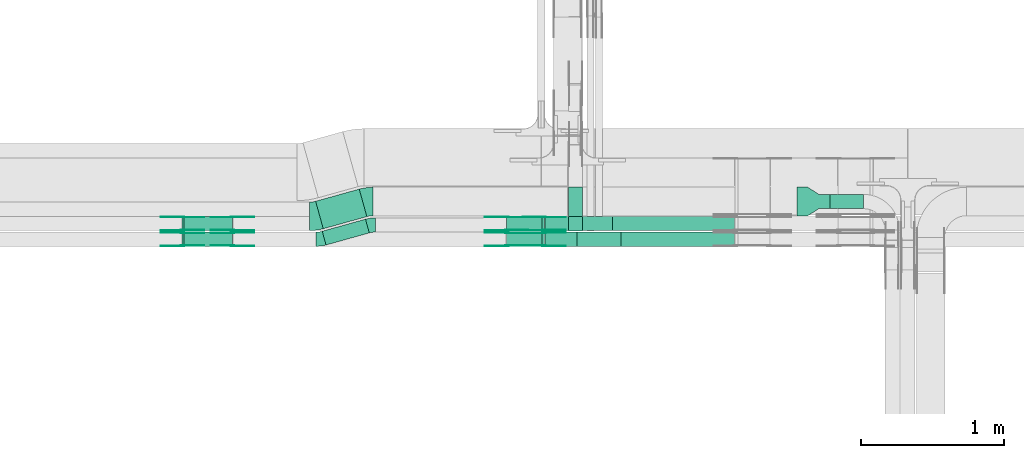
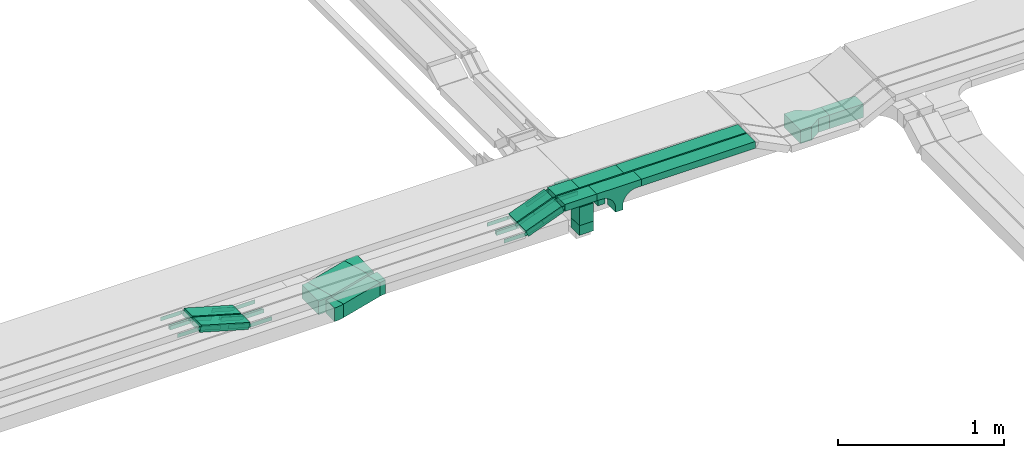
# One storey, part 21 of 28: 40 flow fittings, 12 flow segments.
"""IFC2X3 building model written with IfcOpenShell, lengths in millimetres."""

from ifc_helpers import new_model, entity, si_unit, converted_unit, derived_unit, direction, frame, frame_2d, origin, origin_2d_with_axis, place, context, subcontext, project, spatial, polyline, circle_curve, parameter, trimmed, segment, composite_curve, rectangle, outline, extrude, source, transform, mapped, material, material_list, type_object, type_shapes, element, save


model = new_model("IFC2X3")

# Units and contexts
model_context = context("Model", 3, precision=0.01, world=origin(), true_north=direction((6.12303176911189e-17, 1.0)))
body_context = subcontext(model_context, "Body", "Model", "MODEL_VIEW")
ifc_project = project(units=[si_unit("LENGTHUNIT", "METRE", prefix="MILLI"), si_unit("AREAUNIT", "SQUARE_METRE"), si_unit("VOLUMEUNIT", "CUBIC_METRE"), converted_unit("PLANEANGLEUNIT", "DEGREE", entity("IfcRatioMeasure", 0.0174532925199433), si_unit("PLANEANGLEUNIT", "RADIAN"), dimensions=[0, 0, 0, 0, 0, 0, 0]), si_unit("MASSUNIT", "GRAM", prefix="KILO"), derived_unit("MASSDENSITYUNIT", [(si_unit("MASSUNIT", "GRAM", prefix="KILO"), 1), (si_unit("LENGTHUNIT", "METRE"), -3)]), derived_unit("MOMENTOFINERTIAUNIT", [(si_unit("LENGTHUNIT", "METRE"), 4)]), si_unit("TIMEUNIT", "SECOND"), si_unit("FREQUENCYUNIT", "HERTZ"), si_unit("THERMODYNAMICTEMPERATUREUNIT", "DEGREE_CELSIUS"), derived_unit("THERMALTRANSMITTANCEUNIT", [(si_unit("MASSUNIT", "GRAM", prefix="KILO"), 1), (si_unit("THERMODYNAMICTEMPERATUREUNIT", "KELVIN"), -1), (si_unit("TIMEUNIT", "SECOND"), -3)]), derived_unit("VOLUMETRICFLOWRATEUNIT", [(si_unit("LENGTHUNIT", "METRE"), 3), (si_unit("TIMEUNIT", "SECOND"), -1)]), derived_unit("MASSFLOWRATEUNIT", [(si_unit("MASSUNIT", "GRAM", prefix="KILO"), 1), (si_unit("TIMEUNIT", "SECOND"), -1)]), derived_unit("ROTATIONALFREQUENCYUNIT", [(si_unit("TIMEUNIT", "SECOND"), -1)]), si_unit("ELECTRICCURRENTUNIT", "AMPERE"), si_unit("ELECTRICVOLTAGEUNIT", "VOLT"), si_unit("POWERUNIT", "WATT"), si_unit("FORCEUNIT", "NEWTON", prefix="KILO"), si_unit("ILLUMINANCEUNIT", "LUX"), si_unit("LUMINOUSFLUXUNIT", "LUMEN"), si_unit("LUMINOUSINTENSITYUNIT", "CANDELA"), derived_unit("USERDEFINED", [(si_unit("MASSUNIT", "GRAM", prefix="KILO"), -1), (si_unit("LENGTHUNIT", "METRE"), -2), (si_unit("TIMEUNIT", "SECOND"), 3), (si_unit("LUMINOUSFLUXUNIT", "LUMEN"), 1)]), derived_unit("LINEARVELOCITYUNIT", [(si_unit("LENGTHUNIT", "METRE"), 1), (si_unit("TIMEUNIT", "SECOND"), -1)]), si_unit("PRESSUREUNIT", "PASCAL"), derived_unit("USERDEFINED", [(si_unit("LENGTHUNIT", "METRE"), -2), (si_unit("MASSUNIT", "GRAM", prefix="KILO"), 1), (si_unit("TIMEUNIT", "SECOND"), -2)]), derived_unit("LINEARFORCEUNIT", [(si_unit("MASSUNIT", "GRAM", prefix="KILO"), 1), (si_unit("LENGTHUNIT", "METRE"), 1), (si_unit("TIMEUNIT", "SECOND"), -2), (si_unit("LENGTHUNIT", "METRE"), -1)]), derived_unit("PLANARFORCEUNIT", [(si_unit("MASSUNIT", "GRAM", prefix="KILO"), 1), (si_unit("LENGTHUNIT", "METRE"), 1), (si_unit("TIMEUNIT", "SECOND"), -2), (si_unit("LENGTHUNIT", "METRE"), -2)])], contexts=[model_context])

# Site, building, storey
site_placement = place(None, frame((0.0, -0.00077364408347762, 0.0)))
site = spatial("IfcSite", under=ifc_project, at=site_placement, CompositionType="ELEMENT")
building_placement = place(site_placement, origin())
building = spatial("IfcBuilding", under=site, at=building_placement, CompositionType="ELEMENT")
storey_placement = place(building_placement, origin())
storey = spatial("IfcBuildingStorey", under=building, at=storey_placement, CompositionType="ELEMENT", Elevation=0.0)

# Flow segments
cable_carrier_segment_type = type_object("IfcCableCarrierSegmentType", PredefinedType="CABLETRAYSEGMENT")
flow_segment_1_placement = place(storey_placement, frame((62283.4445429629, 8309.64525919694, 2600.0)))
element("IfcFlowSegment", 1, at=flow_segment_1_placement, inside=storey, type_object=cable_carrier_segment_type, context=body_context, shape_type="SweptSolid", body=[
    extrude(rectangle(XDim=314.534339130373, YDim=99.9999999999995, at=frame_2d((-4.14956957683899e-12, 1.16173737296776e-12), x_axis=(1.0, 0.0))), frame((164.919428102282, 90.4406635474246, 0.0), z_axis=(0.0, 0.0, 1.0), x_axis=(0.963181508900073, 0.268851968400788, 0.0)), (0.0, 0.0, 1.0), 100.0),
])
flow_segment_2_placement = place(storey_placement, frame((62237.2940815141, 8423.32710830691, 2600.0)))
element("IfcFlowSegment", 2, at=flow_segment_2_placement, inside=storey, type_object=cable_carrier_segment_type, context=body_context, shape_type="SweptSolid", body=[
    extrude(rectangle(XDim=316.935834936436, YDim=199.999999999999, at=frame_2d((4.02167188440217e-12, -1.69819713846664e-12), x_axis=(1.0, 0.0))), frame((179.518564699363, 138.922562429709, 0.0), z_axis=(0.0, 0.0, 1.0), x_axis=(0.963181508900077, 0.268851968400775, 0.0)), (0.0, 0.0, 1.0), 99.9999999999999),
])
flow_segment_3_placement = place(storey_placement, frame((64007.7697248974, 8409.3275570197, 2550.0)))
element("IfcFlowSegment", 3, at=flow_segment_3_placement, inside=storey, type_object=cable_carrier_segment_type, context=body_context, shape_type="SweptSolid", body=[
    extrude(rectangle(XDim=99.9999999999946, YDim=100.000000000001, at=origin_2d_with_axis()), frame((50.0, 50.0, 0.0), z_axis=(0.0, 0.0, 1.0), x_axis=(-1.0, 0.0, 0.0)), (0.0, 0.0, 1.0), 70.9999999978977),
])
flow_segment_4_placement = place(storey_placement, frame((61302.9475878774, 8410.00006103511, 2752.36750577514)))
element("IfcFlowSegment", 4, at=flow_segment_4_placement, inside=storey, type_object=cable_carrier_segment_type, context=body_context, shape_type="SweptSolid", body=[
    extrude(rectangle(XDim=49.9999999999995, YDim=100.000000000001, at=frame_2d((0.0, -5.20472553944273e-13), x_axis=(0.0, 1.0))), frame((6.89093389544473, 50.0, 121.233446051265), z_axis=(0.96126169593834, 0.0, -0.275637355816926), x_axis=(0.0, 1.0, 0.0)), (0.0, 0.0, 1.0), 352.64415944179),
])
flow_segment_5_placement = place(storey_placement, frame((61302.9475878774, 8300.0000610352, 2752.36750577514)))
element("IfcFlowSegment", 5, at=flow_segment_5_placement, inside=storey, type_object=cable_carrier_segment_type, context=body_context, shape_type="SweptSolid", body=[
    extrude(rectangle(XDim=49.9999999999984, YDim=99.9999999999989, at=frame_2d((0.0, 0.0), x_axis=(0.0, 1.0))), frame((6.89093389542741, 50.0, 121.233446051261), z_axis=(0.961261695938338, 0.0, -0.275637355816932), x_axis=(0.0, 1.0, 0.0)), (0.0, 0.0, 1.0), 352.644159441781),
])
flow_segment_6_placement = place(storey_placement, frame((65838.1697248974, 8564.3275570197, 2600.0)))
element("IfcFlowSegment", 6, at=flow_segment_6_placement, inside=storey, type_object=cable_carrier_segment_type, context=body_context, shape_type="SweptSolid", body=[
    extrude(rectangle(XDim=235.827601762733, YDim=100.000000000001, at=frame_2d((4.32720526077901e-12, 0.0), x_axis=(1.0, 0.0))), frame((117.913800881371, 50.0, 0.0)), (0.0, 0.0, 1.0), 100.0),
])
flow_segment_7_placement = place(storey_placement, frame((63843.5437252525, 8410.00006103521, 2850.0)))
element("IfcFlowSegment", 7, at=flow_segment_7_placement, inside=storey, type_object=cable_carrier_segment_type, context=body_context, shape_type="SweptSolid", body=[
    extrude(rectangle(XDim=163.625167697005, YDim=100.000000000001, at=frame_2d((0.0, -5.43565192856477e-13), x_axis=(1.0, 0.0))), frame((81.8125838484937, 50.0, 0.0), z_axis=(0.0, 0.0, 1.0), x_axis=(-1.0, 0.0, 0.0)), (0.0, 0.0, 1.0), 50.0000000000005),
])
flow_segment_8_placement = place(storey_placement, frame((63573.652206402, 8410.00006103521, 2753.94502491864)))
element("IfcFlowSegment", 8, at=flow_segment_8_placement, inside=storey, type_object=cable_carrier_segment_type, context=body_context, shape_type="SweptSolid", body=[
    extrude(rectangle(XDim=50.0000000000014, YDim=100.000000000001, at=origin_2d_with_axis()), frame((8.95919873865271, 50.0, 23.3395106624263), z_axis=(0.933580426496962, 0.0, 0.358367949545925), x_axis=(-0.358367949545925, 0.0, 0.933580426496962)), (0.0, 0.0, 1.0), 266.293146356256),
])
flow_segment_9_placement = place(storey_placement, frame((63843.5437252524, 8300.00006103516, 2850.0)))
element("IfcFlowSegment", 9, at=flow_segment_9_placement, inside=storey, type_object=cable_carrier_segment_type, context=body_context, shape_type="SweptSolid", body=[
    extrude(rectangle(XDim=223.777178948546, YDim=99.9999999999989, at=frame_2d((-4.33431068813661e-12, 0.0), x_axis=(1.0, 0.0))), frame((111.888589474277, 50.0, 0.0)), (0.0, 0.0, 1.0), 50.0),
])
flow_segment_10_placement = place(storey_placement, frame((63573.6522064018, 8300.00006103517, 2753.94502491862)))
element("IfcFlowSegment", 10, at=flow_segment_10_placement, inside=storey, type_object=cable_carrier_segment_type, context=body_context, shape_type="SweptSolid", body=[
    extrude(rectangle(XDim=50.0000000000008, YDim=100.000000000001, at=origin_2d_with_axis()), frame((8.95919873864405, 50.0, 23.339510662429), z_axis=(0.933580426497027, 0.0, 0.358367949545756), x_axis=(-0.358367949545756, 0.0, 0.933580426497027)), (0.0, 0.0, 1.0), 266.293146356433),
])
flow_segment_11_placement = place(storey_placement, frame((64317.1688929495, 8410.0000610352, 2850.0)))
element("IfcFlowSegment", 11, at=flow_segment_11_placement, inside=storey, type_object=cable_carrier_segment_type, context=body_context, shape_type="SweptSolid", body=[
    extrude(rectangle(XDim=853.173988896064, YDim=100.000000000001, at=frame_2d((4.32009983342141e-12, 0.0), x_axis=(1.0, 0.0))), frame((426.586994448036, 50.0, 0.0)), (0.0, 0.0, 1.0), 49.9999999999989),
])
flow_segment_12_placement = place(storey_placement, frame((64377.320904201, 8300.00006103515, 2850.0)))
element("IfcFlowSegment", 12, at=flow_segment_12_placement, inside=storey, type_object=cable_carrier_segment_type, context=body_context, shape_type="SweptSolid", body=[
    extrude(rectangle(XDim=793.021977644722, YDim=100.000000000001, at=frame_2d((-4.32009983342141e-12, -5.43565192856477e-13), x_axis=(1.0, 0.0))), frame((396.510988822374, 50.0, 0.0)), (0.0, 0.0, 1.0), 49.9999999999995),
])

# Flow fittings
ifc_material_1 = material(Name="G")
cable_carrier_fitting_type_1 = type_object("IfcCableCarrierFittingType", PredefinedType="NOTDEFINED", material=ifc_material_1)
shared_shape_1 = source(origin(), body_context, "Body", "SweptSolid", [
    extrude(outline(composite_curve([segment(trimmed(circle_curve(frame_2d((-44.5901162790698, 0.0), x_axis=(1.0, 0.0)), 12.5), [parameter(90.0000000000007)], [parameter(270.0)], True, "PARAMETER"), True, "CONTINUOUS"), segment(polyline([(-44.5901162790697, -12.5), (-33.0901162790698, -12.5)]), True, "CONTINUOUS"), segment(polyline([(-33.0901162790698, -12.5), (-31.2296511627907, -14.5)]), True, "CONTINUOUS"), segment(polyline([(-31.2296511627907, -14.5), (108.90988372093, -14.5)]), True, "CONTINUOUS"), segment(polyline([(108.90988372093, -14.5), (108.90988372093, 14.5)]), True, "CONTINUOUS"), segment(polyline([(108.90988372093, 14.5), (-31.2296511627907, 14.5)]), True, "CONTINUOUS"), segment(polyline([(-31.2296511627907, 14.5), (-33.0901162790698, 12.5)]), True, "CONTINUOUS"), segment(polyline([(-33.0901162790698, 12.5), (-44.5901162790699, 12.5)]), True, "CONTINUOUS")], self_intersect=False)), frame((44.5901162790698, 0.0, 0.0), z_axis=(0.0, 0.0, -1.0), x_axis=(1.0, 0.0, 0.0)), (0.0, 0.0, -1.0), 2.0),
])
type_shapes(cable_carrier_fitting_type_1, [shared_shape_1])
for number, where, z_axis, x_axis in (
    (13, (63837.1688929494, 8414.54006102506, 2875.0), (0.0, -1.0, 0.0), (-0.933580426497204, 0.0, -0.358367949545295)),
    (14, (61653.7009053488, 8414.54006102508, 2775.0), (0.0, -1.0, 0.0), (1.0, 0.0, 0.0)),
    (15, (63576.6599864804, 8505.46006104539, 2775.0), (0.0, 1.0, 0.0), (-1.0, 0.0, 0.0)),
    (16, (61653.7009053489, 8304.54006102504, 2775.0), (0.0, -1.0, 0.0), (1.0, 0.0, 0.0)),
    (17, (63576.6599864802, 8395.46006104535, 2775.0), (0.0, 1.0, 0.0), (-1.0, 0.0, 0.0)),
    (18, (63837.1688929494, 8395.46006104533, 2875.0), (0.0, 1.0, 0.0), (1.0, 0.0, 0.0)),
    (19, (61304.9594609646, 8414.54006102495, 2875.0), (0.0, -1.0, 0.0), (-1.0, 0.0, 0.0)),
    (20, (61304.9594609646, 8304.54006102507, 2875.0), (0.0, -1.0, 0.0), (-1.0, 0.0, 0.0)),
):
    element("IfcFlowFitting", number, at=place(storey_placement, frame(where, z_axis=z_axis, x_axis=x_axis)), inside=storey, type_object=cable_carrier_fitting_type_1, material=ifc_material_1, context=body_context, shape_type="MappedRepresentation", body=[
        mapped(shared_shape_1, transform((0.0, 0.0, 0.0), scale=1.0)),
    ])
cable_carrier_fitting_type_2 = type_object("IfcCableCarrierFittingType", PredefinedType="NOTDEFINED", material=ifc_material_1)
shared_shape_2 = source(origin(), body_context, "Body", "SweptSolid", [
    extrude(outline(composite_curve([segment(trimmed(circle_curve(frame_2d((-44.5901162790697, 0.0), x_axis=(1.0, 0.0)), 12.5), [parameter(90.0000000000007)], [parameter(270.0)], True, "PARAMETER"), True, "CONTINUOUS"), segment(polyline([(-44.5901162790697, -12.5), (-33.0901162790697, -12.5)]), True, "CONTINUOUS"), segment(polyline([(-33.0901162790697, -12.5), (-31.2296511627907, -14.5)]), True, "CONTINUOUS"), segment(polyline([(-31.2296511627907, -14.5), (108.90988372093, -14.5)]), True, "CONTINUOUS"), segment(polyline([(108.90988372093, -14.5), (108.90988372093, 14.5)]), True, "CONTINUOUS"), segment(polyline([(108.90988372093, 14.5), (-31.2296511627907, 14.5)]), True, "CONTINUOUS"), segment(polyline([(-31.2296511627907, 14.5), (-33.0901162790698, 12.5)]), True, "CONTINUOUS"), segment(polyline([(-33.0901162790698, 12.5), (-44.5901162790699, 12.5)]), True, "CONTINUOUS")], self_intersect=False)), frame((44.5901162790697, 0.0, 0.0)), (0.0, 0.0, 1.0), 2.0),
])
type_shapes(cable_carrier_fitting_type_2, [shared_shape_2])
for number, where, z_axis, x_axis in (
    (21, (63837.1688929494, 8505.46006104537, 2875.0), (0.0, 1.0, 0.0), (-0.933580426497204, 0.0, -0.358367949545295)),
    (22, (61653.7009053488, 8505.4600610454, 2775.0), (0.0, 1.0, 0.0), (1.0, 0.0, 0.0)),
    (23, (63576.6599864804, 8414.54006102508, 2775.0), (0.0, -1.0, 0.0), (-1.0, 0.0, 0.0)),
    (24, (61653.7009053489, 8395.46006104536, 2775.0), (0.0, 1.0, 0.0), (1.0, 0.0, 0.0)),
    (25, (63576.6599864802, 8304.54006102503, 2775.0), (0.0, -1.0, 0.0), (-1.0, 0.0, 0.0)),
    (26, (63837.1688929494, 8304.54006102501, 2875.0), (0.0, -1.0, 0.0), (1.0, 0.0, 0.0)),
    (27, (61304.9594609646, 8505.46006104527, 2875.0), (0.0, 1.0, 0.0), (-1.0, 0.0, 0.0)),
    (28, (61304.9594609646, 8395.46006104539, 2875.0), (0.0, 1.0, 0.0), (-1.0, 0.0, 0.0)),
):
    element("IfcFlowFitting", number, at=place(storey_placement, frame(where, z_axis=z_axis, x_axis=x_axis)), inside=storey, type_object=cable_carrier_fitting_type_2, material=ifc_material_1, context=body_context, shape_type="MappedRepresentation", body=[
        mapped(shared_shape_2, transform((0.0, 0.0, 0.0), scale=1.0)),
    ])
cable_carrier_fitting_type_3 = type_object("IfcCableCarrierFittingType", PredefinedType="NOTDEFINED", material=ifc_material_1)
shared_shape_3 = source(origin(), body_context, "Body", "SweptSolid", [
    extrude(outline(composite_curve([segment(trimmed(circle_curve(frame_2d((-44.5901162790698, 0.0), x_axis=(1.0, 0.0)), 12.5), [parameter(90.0000000000007)], [parameter(270.0)], True, "PARAMETER"), True, "CONTINUOUS"), segment(polyline([(-44.5901162790697, -12.5), (-33.0901162790698, -12.5)]), True, "CONTINUOUS"), segment(polyline([(-33.0901162790698, -12.5), (-31.2296511627907, -14.5)]), True, "CONTINUOUS"), segment(polyline([(-31.2296511627907, -14.5), (108.90988372093, -14.5)]), True, "CONTINUOUS"), segment(polyline([(108.90988372093, -14.5), (108.90988372093, 14.5)]), True, "CONTINUOUS"), segment(polyline([(108.90988372093, 14.5), (-31.2296511627907, 14.5)]), True, "CONTINUOUS"), segment(polyline([(-31.2296511627907, 14.5), (-33.0901162790698, 12.5)]), True, "CONTINUOUS"), segment(polyline([(-33.0901162790698, 12.5), (-44.5901162790699, 12.5)]), True, "CONTINUOUS")], self_intersect=False)), frame((44.5901162790698, 0.0, 0.0), z_axis=(0.0, 0.0, -1.0), x_axis=(1.0, 0.0, 0.0)), (0.0, 0.0, -1.0), 2.0),
])
type_shapes(cable_carrier_fitting_type_3, [shared_shape_3])
for number, where, z_axis, x_axis in (
    (29, (63837.1688929494, 8503.46006104537, 2875.0), (0.0, 1.0, 0.0), (1.0, 0.0, 0.0)),
    (30, (61653.7009053489, 8503.4600610454, 2775.0), (0.0, 1.0, 0.0), (-0.961261695938351, 0.0, 0.275637355816886)),
    (31, (63576.6599864803, 8416.54006102507, 2775.0), (0.0, -1.0, 0.0), (0.93358042649699, 0.0, 0.358367949545852)),
    (32, (61653.7009053489, 8393.46006104536, 2775.0), (0.0, 1.0, 0.0), (-0.961261695938352, 0.0, 0.275637355816883)),
    (33, (63576.6599864802, 8306.54006102503, 2775.0), (0.0, -1.0, 0.0), (0.933580426497054, 0.0, 0.358367949545685)),
    (34, (63837.1688929494, 8306.54006102501, 2875.0), (0.0, -1.0, 0.0), (-0.933580426497046, 0.0, -0.358367949545707)),
    (35, (61304.9594609646, 8503.46006104527, 2875.0), (0.0, 1.0, 0.0), (0.961261695938351, 0.0, -0.275637355816886)),
    (36, (61304.9594609646, 8393.46006104539, 2875.0), (0.0, 1.0, 0.0), (0.961261695938352, 0.0, -0.275637355816883)),
):
    element("IfcFlowFitting", number, at=place(storey_placement, frame(where, z_axis=z_axis, x_axis=x_axis)), inside=storey, type_object=cable_carrier_fitting_type_3, material=ifc_material_1, context=body_context, shape_type="MappedRepresentation", body=[
        mapped(shared_shape_3, transform((0.0, 0.0, 0.0), scale=1.0)),
    ])
cable_carrier_fitting_type_4 = type_object("IfcCableCarrierFittingType", PredefinedType="NOTDEFINED", material=ifc_material_1)
shared_shape_4 = source(origin(), body_context, "Body", "SweptSolid", [
    extrude(outline(composite_curve([segment(trimmed(circle_curve(frame_2d((-44.5901162790697, 0.0), x_axis=(1.0, 0.0)), 12.5), [parameter(90.0000000000007)], [parameter(270.0)], True, "PARAMETER"), True, "CONTINUOUS"), segment(polyline([(-44.5901162790697, -12.5), (-33.0901162790697, -12.5)]), True, "CONTINUOUS"), segment(polyline([(-33.0901162790697, -12.5), (-31.2296511627907, -14.5)]), True, "CONTINUOUS"), segment(polyline([(-31.2296511627907, -14.5), (108.90988372093, -14.5)]), True, "CONTINUOUS"), segment(polyline([(108.90988372093, -14.5), (108.90988372093, 14.5)]), True, "CONTINUOUS"), segment(polyline([(108.90988372093, 14.5), (-31.2296511627907, 14.5)]), True, "CONTINUOUS"), segment(polyline([(-31.2296511627907, 14.5), (-33.0901162790698, 12.5)]), True, "CONTINUOUS"), segment(polyline([(-33.0901162790698, 12.5), (-44.5901162790699, 12.5)]), True, "CONTINUOUS")], self_intersect=False)), frame((44.5901162790697, 0.0, 0.0)), (0.0, 0.0, 1.0), 2.0),
])
type_shapes(cable_carrier_fitting_type_4, [shared_shape_4])
for number, where, z_axis, x_axis in (
    (37, (63837.1688929494, 8416.54006102506, 2875.0), (0.0, -1.0, 0.0), (1.0, 0.0, 0.0)),
    (38, (61653.7009053489, 8416.54006102509, 2775.0), (0.0, -1.0, 0.0), (-0.961261695938351, 0.0, 0.275637355816886)),
    (39, (63576.6599864803, 8503.46006104539, 2775.0), (0.0, 1.0, 0.0), (0.93358042649699, 0.0, 0.358367949545852)),
    (40, (61653.7009053489, 8306.54006102504, 2775.0), (0.0, -1.0, 0.0), (-0.961261695938352, 0.0, 0.275637355816883)),
    (41, (63576.6599864802, 8393.46006104534, 2775.0), (0.0, 1.0, 0.0), (0.933580426497054, 0.0, 0.358367949545685)),
    (42, (63837.1688929494, 8393.46006104533, 2875.0), (0.0, 1.0, 0.0), (-0.933580426497046, 0.0, -0.358367949545707)),
    (43, (61304.9594609646, 8416.54006102496, 2875.0), (0.0, -1.0, 0.0), (0.961261695938351, 0.0, -0.275637355816886)),
    (44, (61304.9594609646, 8306.54006102507, 2875.0), (0.0, -1.0, 0.0), (0.961261695938352, 0.0, -0.275637355816883)),
):
    element("IfcFlowFitting", number, at=place(storey_placement, frame(where, z_axis=z_axis, x_axis=x_axis)), inside=storey, type_object=cable_carrier_fitting_type_4, material=ifc_material_1, context=body_context, shape_type="MappedRepresentation", body=[
        mapped(shared_shape_4, transform((0.0, 0.0, 0.0), scale=1.0)),
    ])
ifc_material_2 = material()
cable_carrier_fitting_type_5 = type_object("IfcCableCarrierFittingType", Name="470_DKC_S5_Variable Angle Elbow 0-45:-", PredefinedType="NOTDEFINED", material=ifc_material_2)
shared_shape_5 = source(origin(), body_context, "Body", "SweptSolid", [
    extrude(outline(composite_curve([segment(polyline([(-27.8759922173, -53.7490621020919), (-26.8759922172987, -53.7490621020919)]), True, "CONTINUOUS"), segment(trimmed(circle_curve(frame_2d((-26.8759922173012, 196.250937897908), x_axis=(0.0, -1.0)), 250.0), [parameter(0.0)], [parameter(15.5959637059961)], True, "PARAMETER"), True, "CONTINUOUS"), segment(polyline([(40.3369998828871, -44.5444393271126), (41.3001813917871, -44.2755873587118)]), True, "CONTINUOUS"), segment(polyline([(41.3001813917871, -44.2755873587119), (14.4149845517119, 52.0425635312964)]), True, "CONTINUOUS"), segment(polyline([(14.4149845517119, 52.0425635312964), (13.4518030428118, 51.7737115628956)]), True, "CONTINUOUS"), segment(trimmed(circle_curve(frame_2d((-26.8759922173012, 196.250937897908), x_axis=(0.0, -1.0)), 150.0), [parameter(0.0)], [parameter(15.5959637059961)], True, "PARAMETER"), False, "CONTINUOUS"), segment(polyline([(-26.8759922172995, 46.250937897908), (-27.8759922173008, 46.250937897908)]), True, "CONTINUOUS"), segment(polyline([(-27.8759922173008, 46.250937897908), (-27.8759922173, -53.7490621020919)]), True, "CONTINUOUS")], self_intersect=False)), frame((-0.513423094713987, 3.74906210208359, -50.0)), (0.0, 0.0, 1.0), 100.0),
])
type_shapes(cable_carrier_fitting_type_5, [shared_shape_5])
flow_fitting_1_placement = place(storey_placement, frame((62627.1849606245, 8450.00006103515, 2650.0), z_axis=(0.0, 0.0, 1.0), x_axis=(-1.0, 0.0, 0.0)))
element("IfcFlowFitting", 45, at=flow_fitting_1_placement, inside=storey, type_object=cable_carrier_fitting_type_5, material=ifc_material_2, Name="470_DKC_S5_Variable Angle Elbow 0-45:-", ObjectType="470_DKC_S5_Variable Angle Elbow 0-45:-", context=body_context, shape_type="MappedRepresentation", body=[
    mapped(shared_shape_5, transform((0.0, 0.0, 0.0), scale=1.0)),
])
flow_fitting_2_placement = place(storey_placement, frame((62269.5429815059, 8350.17178445358, 2650.0)))
element("IfcFlowFitting", 46, at=flow_fitting_2_placement, inside=storey, type_object=cable_carrier_fitting_type_5, material=ifc_material_2, Name="470_DKC_S5_Variable Angle Elbow 0-45:-", ObjectType="470_DKC_S5_Variable Angle Elbow 0-45:-", context=body_context, shape_type="MappedRepresentation", body=[
    mapped(shared_shape_5, transform((0.0, 0.0, 0.0), scale=1.0)),
])
ifc_material_list_1 = material_list([ifc_material_2, ifc_material_2, ifc_material_2, ifc_material_2, ifc_material_2])
ifc_material_list_2 = material_list([ifc_material_2, ifc_material_2, ifc_material_2, ifc_material_2, ifc_material_2])
cable_carrier_fitting_type_6 = type_object("IfcCableCarrierFittingType", PredefinedType="NOTDEFINED", material=ifc_material_list_2)
shared_shape_6 = source(origin(), body_context, "Body", "SweptSolid", [
    extrude(outline(composite_curve([segment(polyline([(-61.8571428571422, -174.285714285714), (-7.85714285714298, -174.285714285714)]), True, "CONTINUOUS"), segment(polyline([(-7.85714285714298, -174.285714285714), (-7.85714285714366, 25.7142857142864)]), True, "CONTINUOUS"), segment(trimmed(circle_curve(frame_2d((-2.85714285714366, 25.7142857142864), x_axis=(0.0, -1.0)), 5.0), [parameter(180.0)], [parameter(270.0)], True, "PARAMETER"), False, "CONTINUOUS"), segment(polyline([(-2.85714285714365, 30.7142857142857), (71.1428571428574, 30.7142857142857)]), True, "CONTINUOUS"), segment(polyline([(71.1428571428574, 30.7142857142857), (71.1428571428574, 130.714285714286)]), True, "CONTINUOUS"), segment(polyline([(71.1428571428574, 130.714285714286), (-61.8571428571422, 130.714285714286)]), True, "CONTINUOUS"), segment(polyline([(-61.8571428571422, 130.714285714286), (-61.8571428571422, -174.285714285714)]), True, "CONTINUOUS")], self_intersect=False)), frame((-74.2857142857142, -50.0, 42.1428571428574), z_axis=(0.0, 1.0, 0.0), x_axis=(0.0, 0.0, -1.0)), (0.0, 0.0, 1.0), 0.800000000000055),
    extrude(rectangle(XDim=0.799999999999954, YDim=100.0, at=origin_2d_with_axis()), frame((99.6, 0.0, 17.5000000000609), z_axis=(0.0, 0.0, 1.0), x_axis=(-1.0, 0.0, 0.0)), (0.0, 0.0, 1.0), 86.4999999999732),
    extrude(rectangle(XDim=305.0, YDim=100.0, at=origin_2d_with_axis()), frame((-52.4999999999998, 0.0, 103.199999999999), z_axis=(0.0, 0.0, 1.0), x_axis=(-1.0, 0.0, 0.0)), (0.0, 0.0, 1.0), 0.800000000000106),
    extrude(rectangle(XDim=0.799999999999852, YDim=98.4000000000001, at=frame_2d((-1.69309011255336e-14, 0.0), x_axis=(1.0, 0.0))), frame((-204.6, 0.0, -29.0), z_axis=(0.0, 0.0, 1.0), x_axis=(-1.0, 0.0, 0.0)), (0.0, 0.0, 1.0), 133.0),
    extrude(outline(composite_curve([segment(polyline([(-61.8571428571426, -174.285714285714), (-7.8571428571429, -174.285714285714)]), True, "CONTINUOUS"), segment(polyline([(-7.8571428571429, -174.285714285714), (-7.8571428571429, 25.7142857142858)]), True, "CONTINUOUS"), segment(trimmed(circle_curve(frame_2d((-2.85714285714291, 25.7142857142858), x_axis=(0.0, -1.0)), 5.0), [parameter(180.0)], [parameter(270.0)], True, "PARAMETER"), False, "CONTINUOUS"), segment(polyline([(-2.85714285714293, 30.7142857142858), (71.1428571428569, 30.7142857142858)]), True, "CONTINUOUS"), segment(polyline([(71.1428571428569, 30.7142857142858), (71.1428571428569, 130.714285714286)]), True, "CONTINUOUS"), segment(polyline([(71.1428571428569, 130.714285714286), (-61.8571428571426, 130.714285714286)]), True, "CONTINUOUS"), segment(polyline([(-61.8571428571426, 130.714285714286), (-61.8571428571426, -174.285714285714)]), True, "CONTINUOUS")], self_intersect=False)), frame((-74.2857142857142, 49.2000000000002, 42.1428571428575), z_axis=(0.0, 1.0, 0.0), x_axis=(0.0, 0.0, -1.0)), (0.0, 0.0, 1.0), 0.799999999999835),
])
type_shapes(cable_carrier_fitting_type_6, [shared_shape_6])
flow_fitting_3_placement = place(storey_placement, frame((64057.7697248974, 8614.3275570197, 2650.0), z_axis=(0.0, 0.0, 1.0), x_axis=(0.0, 1.0, 0.0)))
element("IfcFlowFitting", 47, at=flow_fitting_3_placement, inside=storey, type_object=cable_carrier_fitting_type_6, material=ifc_material_list_1, Name="470_DKC_S5_vertical T-shaped cover", context=body_context, shape_type="MappedRepresentation", body=[
    mapped(shared_shape_6, transform((0.0, 0.0, 0.0), scale=1.0)),
])
cable_carrier_fitting_type_7 = type_object("IfcCableCarrierFittingType", Name="470_DKC_S5_Variable Angle Elbow 0-45:-", PredefinedType="NOTDEFINED", material=ifc_material_2)
shared_shape_7 = source(origin(), body_context, "Body", "SweptSolid", [
    extrude(outline(composite_curve([segment(polyline([(-34.597291427323, -104.669524379591), (-33.5972914273215, -104.669524379591)]), True, "CONTINUOUS"), segment(trimmed(circle_curve(frame_2d((-33.5972914273221, 245.330475620409), x_axis=(0.0, -1.0)), 350.0), [parameter(0.0)], [parameter(15.5959637059979)], True, "PARAMETER"), True, "CONTINUOUS"), segment(polyline([(60.5008975129495, -91.7830524946174), (61.4640790218489, -91.5142005262168)]), True, "CONTINUOUS"), segment(polyline([(61.4640790218489, -91.5142005262168), (7.69368534169493, 101.122101253799)]), True, "CONTINUOUS"), segment(polyline([(7.69368534169494, 101.122101253799), (6.73050383279426, 100.853249285398)]), True, "CONTINUOUS"), segment(trimmed(circle_curve(frame_2d((-33.5972914273221, 245.330475620409), x_axis=(0.0, -1.0)), 150.0), [parameter(0.0)], [parameter(15.5959637059979)], True, "PARAMETER"), False, "CONTINUOUS"), segment(polyline([(-33.5972914273215, 95.3304756204093), (-34.597291427323, 95.3304756204093)]), True, "CONTINUOUS"), segment(polyline([(-34.597291427323, 95.3304756204093), (-34.597291427323, -104.669524379591)]), True, "CONTINUOUS")], self_intersect=False)), frame((-0.639477712701265, 4.66952437958255, -50.0)), (0.0, 0.0, 1.0), 100.0),
])
type_shapes(cable_carrier_fitting_type_7, [shared_shape_7])
flow_fitting_4_placement = place(storey_placement, frame((62603.3854185418, 8614.32755701968, 2650.0), z_axis=(0.0, 0.0, 1.0), x_axis=(-1.0, 0.0, 0.0)))
element("IfcFlowFitting", 48, at=flow_fitting_4_placement, inside=storey, type_object=cable_carrier_fitting_type_7, material=ifc_material_2, Name="470_DKC_S5_Variable Angle Elbow 0-45:-", ObjectType="470_DKC_S5_Variable Angle Elbow 0-45:-", context=body_context, shape_type="MappedRepresentation", body=[
    mapped(shared_shape_7, transform((0.0, 0.0, 0.0), scale=1.0)),
])
flow_fitting_5_placement = place(storey_placement, frame((62230.2398738851, 8510.17178445355, 2650.0)))
element("IfcFlowFitting", 49, at=flow_fitting_5_placement, inside=storey, type_object=cable_carrier_fitting_type_7, material=ifc_material_2, Name="470_DKC_S5_Variable Angle Elbow 0-45:-", ObjectType="470_DKC_S5_Variable Angle Elbow 0-45:-", context=body_context, shape_type="MappedRepresentation", body=[
    mapped(shared_shape_7, transform((0.0, 0.0, 0.0), scale=1.0)),
])
cable_carrier_fitting_type_8 = type_object("IfcCableCarrierFittingType", PredefinedType="NOTDEFINED", material=ifc_material_2)
shared_shape_8 = source(origin(), body_context, "Body", "SweptSolid", [
    extrude(outline(composite_curve([segment(polyline([(-155.0, -85.7999999999954), (155.0, -85.7999999999954)]), True, "CONTINUOUS"), segment(polyline([(155.0, -85.7999999999954), (155.0, -35.7999999999878)]), True, "CONTINUOUS"), segment(polyline([(155.0, -35.7999999999878), (125.0, -35.7999999999878)]), True, "CONTINUOUS"), segment(trimmed(circle_curve(frame_2d((125.0, 64.2000000000048), x_axis=(1.0, 0.0)), 99.9999999999926), [parameter(180.0)], [parameter(269.999999999985)], True, "PARAMETER"), False, "CONTINUOUS"), segment(polyline([(25.0, 64.2000000000045), (25.0, 93.2000000000039)]), True, "CONTINUOUS"), segment(polyline([(25.0, 93.2000000000039), (-25.0, 93.2000000000039)]), True, "CONTINUOUS"), segment(polyline([(-25.0, 93.2000000000039), (-25.0, 64.1999999999235)]), True, "CONTINUOUS"), segment(trimmed(circle_curve(frame_2d((-125.0, 64.2000000000028), x_axis=(1.0, 0.0)), 99.9999999999768), [parameter(270.0)], [parameter(359.999999999955)], True, "PARAMETER"), False, "CONTINUOUS"), segment(polyline([(-125.0, -35.799999999974), (-155.0, -35.7999999999955)]), True, "CONTINUOUS"), segment(polyline([(-155.0, -35.7999999999955), (-155.0, -85.7999999999954)]), True, "CONTINUOUS")], self_intersect=False)), frame((155.0, -50.0, -60.7999999999977), z_axis=(0.0, 1.0, 0.0), x_axis=(1.0, 0.0, 0.0)), (0.0, 0.0, 1.0), 100.0),
])
type_shapes(cable_carrier_fitting_type_8, [shared_shape_8])
for number, where, z_axis, x_axis in (
    (50, (64317.1688929495, 8460.00006103519, 2875.0), (0.0, 0.0, 1.0), (-1.0, 0.0, 0.0)),
    (51, (64377.320904201, 8350.00006103515, 2875.0), (0.0, 0.0, 1.0), (-1.0, 0.0, 0.0)),
):
    element("IfcFlowFitting", number, at=place(storey_placement, frame(where, z_axis=z_axis, x_axis=x_axis)), inside=storey, type_object=cable_carrier_fitting_type_8, material=ifc_material_2, context=body_context, shape_type="MappedRepresentation", body=[
        mapped(shared_shape_8, transform((0.0, 0.0, 0.0), scale=1.0)),
    ])
cable_carrier_fitting_type_9 = type_object("IfcCableCarrierFittingType", PredefinedType="NOTDEFINED", material=ifc_material_2)
shared_shape_9 = source(origin(), body_context, "Body", "SweptSolid", [
    extrude(outline(polyline([(-115.0, 50.0), (-115.0, -50.0), (-38.3333333333284, -50.0), (38.3333333333382, -100.0), (115.0, -100.0), (115.0, 100.0), (38.3333333333252, 100.0), (-38.3333333333284, 50.0), (-115.0, 50.0)])), frame((115.0, 0.0, -50.0), z_axis=(0.0, 0.0, -1.0), x_axis=(1.0, 0.0, 0.0)), (0.0, 0.0, -1.0), 100.0),
])
type_shapes(cable_carrier_fitting_type_9, [shared_shape_9])
flow_fitting_6_placement = place(storey_placement, frame((65838.1697248974, 8614.3275570197, 2650.0), z_axis=(0.0, 0.0, 1.0), x_axis=(-1.0, 0.0, 0.0)))
element("IfcFlowFitting", 52, at=flow_fitting_6_placement, inside=storey, type_object=cable_carrier_fitting_type_9, material=ifc_material_2, Name="470_DKC_S5_adapter", context=body_context, shape_type="MappedRepresentation", body=[
    mapped(shared_shape_9, transform((0.0, 0.0, 0.0), scale=1.0)),
])

save(model, "model.ifc")
